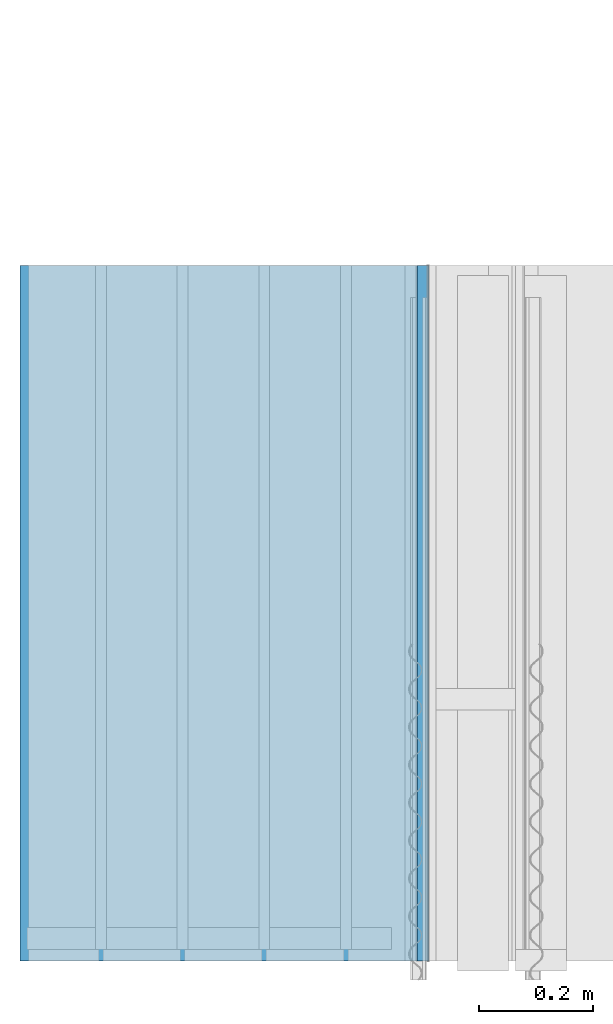
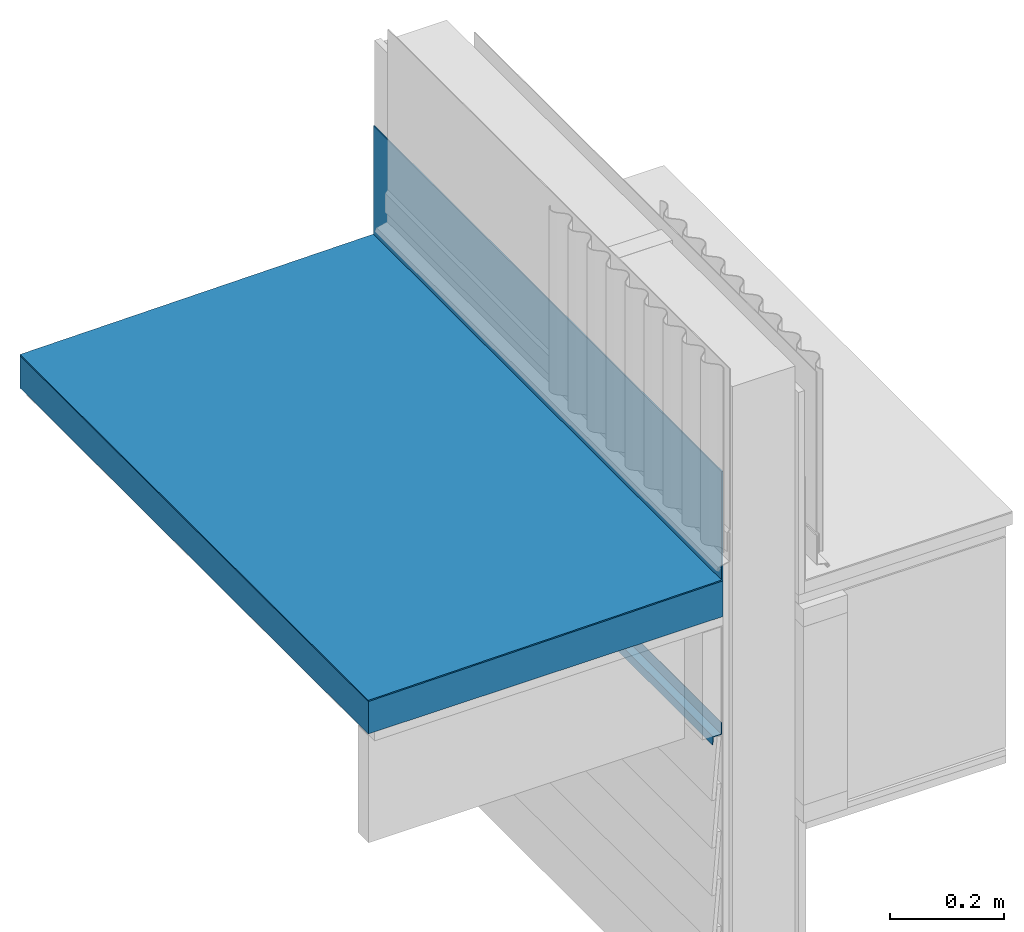
# One storey, part 8 of 33: 3 walls.
"""IFC4 building model written with IfcOpenShell, lengths in feet."""

import ifcopenshell
import ifcopenshell.guid

model = None  # the IFC model being written
_history = None  # IfcOwnerHistory: only IFC2X3 demands one
_inside = {}  # id of a spatial element -> (the spatial element, [elements in it])
_under = {}  # id of a project, library or spatial element -> (it, [spatial elements below it])
_declared = {}  # id of a project -> (the project, [libraries it declares])
_typed = {}  # id of a type object -> (the type object, [elements of that type])
_made_of = {}  # id of a material, layer set ... -> (it, [elements and type objects made of it])


def new_model(schema):
    """Start an empty IFC model of exactly this schema.

    Asked for "IFC4X3", IfcOpenShell would pick the latest addendum, in which some entities
    have other attributes; the version numbers below select the first issue.
    IFC2X3 requires an IfcOwnerHistory on every rooted entity: one is made here for all.
    """
    global model, _history
    if schema == "IFC4X3":
        model = ifcopenshell.file(schema_version=(4, 3, 0, 0))
    else:
        model = ifcopenshell.file(schema=schema)
    _inside.clear()
    _under.clear()
    _declared.clear()
    _typed.clear()
    _made_of.clear()
    _history = None
    if model.schema == "IFC2X3":
        org = make("IfcOrganization", Name="unknown")
        user = make(
            "IfcPersonAndOrganization",
            ThePerson=make("IfcPerson", FamilyName="unknown"),
            TheOrganization=org,
        )
        app = make(
            "IfcApplication",
            ApplicationDeveloper=org,
            Version="unknown",
            ApplicationFullName="unknown",
            ApplicationIdentifier="unknown",
        )
        _history = make(
            "IfcOwnerHistory",
            OwningUser=user,
            OwningApplication=app,
            ChangeAction="ADDED",
            CreationDate=0,
        )
    return model


def make(cls, **values):
    """One entity of the class cls with the attributes given. An attribute that is None is left unset."""
    return model.create_entity(
        cls, **{name: value for name, value in values.items() if value is not None}
    )


def entity(cls, *values):
    """Any entity or typed value of the class cls, its attributes in the order of the schema. None: left unset."""
    e = model.create_entity(cls)
    for i, value in enumerate(values):
        if value is not None:
            e[i] = value
    return e


def rooted(cls, **values):
    """An entity with a GlobalId (a new one), such as an element, a storey or a relation."""
    return make(cls, GlobalId=ifcopenshell.guid.new(), OwnerHistory=_history, **values)


def si_unit(unit_type, name, prefix=None):
    """IfcSIUnit, for example si_unit("LENGTHUNIT", "METRE", prefix="MILLI")."""
    return make("IfcSIUnit", UnitType=unit_type, Prefix=prefix, Name=name)


def converted_unit(unit_type, name, factor, base, dimensions=None, offset=None):
    """IfcConversionBasedUnit, such as the inch: factor (a typed value) times the base unit."""
    return make(
        "IfcConversionBasedUnit"
        if offset is None
        else "IfcConversionBasedUnitWithOffset",
        ConversionOffset=offset,
        Dimensions=None
        if dimensions is None
        else entity("IfcDimensionalExponents", *dimensions),
        UnitType=unit_type,
        Name=name,
        ConversionFactor=make(
            "IfcMeasureWithUnit", ValueComponent=factor, UnitComponent=base
        ),
    )


def derived_unit(unit_type, elements):
    """IfcDerivedUnit: a product of units, each with its exponent."""
    return make(
        "IfcDerivedUnit",
        Elements=[
            make("IfcDerivedUnitElement", Unit=unit, Exponent=power)
            for unit, power in elements
        ],
        UnitType=unit_type,
    )


def assignment(units):
    """IfcUnitAssignment: the units of a project."""
    return None if units is None else make("IfcUnitAssignment", Units=units)


def point(xyz):
    """IfcCartesianPoint."""
    return None if xyz is None else make("IfcCartesianPoint", Coordinates=xyz)


def direction(xyz):
    """IfcDirection."""
    return None if xyz is None else make("IfcDirection", DirectionRatios=xyz)


def frame(location, z_axis=None, x_axis=None):
    """IfcAxis2Placement3D, a coordinate frame: its origin and axes. An axis left out is left unset."""
    return make(
        "IfcAxis2Placement3D",
        Location=point(location),
        Axis=direction(z_axis),
        RefDirection=direction(x_axis),
    )


def origin():
    """The frame at (0, 0, 0) with its axes left unset."""
    return frame((0.0, 0.0, 0.0))


def place(relative_to, where):
    """IfcLocalPlacement: puts the frame where relative to a parent placement (None: the world)."""
    return make(
        "IfcLocalPlacement", PlacementRelTo=relative_to, RelativePlacement=where
    )


def context(
    kind, dimensions, precision=None, world=None, true_north=None, identifier=None
):
    """IfcGeometricRepresentationContext, for example the 3D "Model" context."""
    return make(
        "IfcGeometricRepresentationContext",
        ContextIdentifier=identifier,
        ContextType=kind,
        CoordinateSpaceDimension=dimensions,
        Precision=precision,
        WorldCoordinateSystem=world,
        TrueNorth=true_north,
    )


def subcontext(parent, identifier, kind, view, scale=None):
    """IfcGeometricRepresentationSubContext, for example "Body" below "Model"."""
    return make(
        "IfcGeometricRepresentationSubContext",
        ContextIdentifier=identifier,
        ContextType=kind,
        ParentContext=parent,
        TargetScale=scale,
        TargetView=view,
    )


def project(units=None, contexts=None):
    """IfcProject with its units and contexts."""
    return rooted(
        "IfcProject",
        Name="project",
        RepresentationContexts=contexts,
        UnitsInContext=assignment(units),
    )


def spatial(cls, under=None, at=None, **own):
    """A site, building, storey or space (cls), placed at a placement, below another one or the project."""
    s = rooted(cls, ObjectPlacement=at, **own)
    if under is not None:
        _under.setdefault(under.id(), (under, []))[1].append(s)
    return s


def shape(context_of_items, identifier, shape_type, items):
    """IfcShapeRepresentation: the items that make up one representation, for example the "Body"."""
    return make(
        "IfcShapeRepresentation",
        ContextOfItems=context_of_items,
        RepresentationIdentifier=identifier,
        RepresentationType=shape_type,
        Items=items,
    )


def material(Name=None, Category=None):
    """IfcMaterial."""
    return make("IfcMaterial", Name=Name, Category=Category)


def made_of(thing, what):
    """Note that an element or type object is made of a material, layer set ...; save() writes the relation."""
    if what is not None:
        _made_of.setdefault(what.id(), (what, []))[1].append(thing)
    return thing


def type_object(cls, material=None, **own):
    """A type object (cls), such as IfcWallType, which elements share."""
    return made_of(rooted(cls, **own), material)


def element(
    cls,
    number,
    at=None,
    inside=None,
    cuts=None,
    type_object=None,
    material=None,
    context=None,
    identifier="Body",
    shape_type=None,
    held_by="IfcProductDefinitionShape",
    body=None,
    shapes=None,
    **own,
):
    """One element of the class cls, such as IfcWall. Its Tag is "e" and its number.

    at: its placement. inside: the storey or other place that contains it. cuts: it is an
    opening in that element (IfcRelVoidsElement). A single representation is given by context,
    identifier, shape_type and body (its items); several are given by shapes. held_by: the class
    of the entity that holds the representations. save() writes the other relations.
    """
    e = rooted(cls, Tag="e%d" % number, ObjectPlacement=at, **own)
    if body is not None:
        shapes = [shape(context, identifier, shape_type, body)]
    if shapes is not None:
        e.Representation = make(held_by, Representations=shapes)
    if inside is not None:
        _inside.setdefault(inside.id(), (inside, []))[1].append(e)
    if cuts is not None:
        rooted(
            "IfcRelVoidsElement", RelatingBuildingElement=cuts, RelatedOpeningElement=e
        )
    if type_object is not None:
        _typed.setdefault(type_object.id(), (type_object, []))[1].append(e)
    return made_of(e, material)


def aggregate(whole, parts):
    """IfcRelAggregates: a whole, such as a stair, and the parts it consists of."""
    return rooted("IfcRelAggregates", RelatingObject=whole, RelatedObjects=parts)


def save(model, path):
    """Write the relations noted so far, then the file.

    IfcRelAggregates (storeys below a building ...), IfcRelContainedInSpatialStructure (elements
    in a storey), IfcRelDefinesByType, IfcRelAssociatesMaterial and IfcRelDeclares: one each for
    every whole, place, type object, material and project.
    """
    for whole, parts in _under.values():
        aggregate(whole, parts)
    for where, things in _inside.values():
        rooted(
            "IfcRelContainedInSpatialStructure",
            RelatedElements=things,
            RelatingStructure=where,
        )
    for kind, things in _typed.values():
        rooted("IfcRelDefinesByType", RelatedObjects=things, RelatingType=kind)
    for what, things in _made_of.values():
        rooted("IfcRelAssociatesMaterial", RelatedObjects=things, RelatingMaterial=what)
    for by, libraries in _declared.values():
        rooted("IfcRelDeclares", RelatingContext=by, RelatedDefinitions=libraries)
    model.write(path)


model = new_model("IFC4")

# Units and contexts
model_context = context("Model", 3, precision=0.0001, world=origin(), true_north=direction((6.12303176911189e-17, 1.0)))
body_context = subcontext(model_context, "Body", "Model", "MODEL_VIEW")
ifc_project = project(units=[converted_unit("LENGTHUNIT", "FOOT", entity("IfcRatioMeasure", 0.3048), si_unit("LENGTHUNIT", "METRE"), dimensions=[1, 0, 0, 0, 0, 0, 0]), converted_unit("AREAUNIT", "SQUARE FOOT", entity("IfcRatioMeasure", 0.09290304), si_unit("AREAUNIT", "SQUARE_METRE"), dimensions=[2, 0, 0, 0, 0, 0, 0]), converted_unit("VOLUMEUNIT", "CUBIC FOOT", entity("IfcRatioMeasure", 0.028316846592), si_unit("VOLUMEUNIT", "CUBIC_METRE"), dimensions=[3, 0, 0, 0, 0, 0, 0]), converted_unit("PLANEANGLEUNIT", "DEGREE", entity("IfcRatioMeasure", 0.0174532925199433), si_unit("PLANEANGLEUNIT", "RADIAN"), dimensions=[0, 0, 0, 0, 0, 0, 0]), si_unit("MASSUNIT", "GRAM", prefix="KILO"), derived_unit("MASSDENSITYUNIT", [(si_unit("MASSUNIT", "GRAM", prefix="KILO"), 1), (si_unit("LENGTHUNIT", "METRE"), -3)]), derived_unit("MOMENTOFINERTIAUNIT", [(si_unit("LENGTHUNIT", "METRE"), 4)]), si_unit("TIMEUNIT", "SECOND"), si_unit("FREQUENCYUNIT", "HERTZ"), si_unit("THERMODYNAMICTEMPERATUREUNIT", "DEGREE_CELSIUS"), derived_unit("THERMALTRANSMITTANCEUNIT", [(si_unit("MASSUNIT", "GRAM", prefix="KILO"), 1), (si_unit("THERMODYNAMICTEMPERATUREUNIT", "KELVIN"), -1), (si_unit("TIMEUNIT", "SECOND"), -3)]), derived_unit("VOLUMETRICFLOWRATEUNIT", [(si_unit("LENGTHUNIT", "METRE"), 3), (si_unit("TIMEUNIT", "SECOND"), -1)]), si_unit("ELECTRICCURRENTUNIT", "AMPERE"), si_unit("ELECTRICVOLTAGEUNIT", "VOLT"), si_unit("POWERUNIT", "WATT"), si_unit("FORCEUNIT", "NEWTON"), si_unit("ILLUMINANCEUNIT", "LUX"), si_unit("LUMINOUSFLUXUNIT", "LUMEN"), si_unit("LUMINOUSINTENSITYUNIT", "CANDELA"), derived_unit("USERDEFINED", [(si_unit("MASSUNIT", "GRAM", prefix="KILO"), -1), (si_unit("LENGTHUNIT", "METRE"), -2), (si_unit("TIMEUNIT", "SECOND"), 3), (si_unit("LUMINOUSFLUXUNIT", "LUMEN"), 1)]), derived_unit("LINEARVELOCITYUNIT", [(si_unit("LENGTHUNIT", "METRE"), 1), (si_unit("TIMEUNIT", "SECOND"), -1)]), si_unit("PRESSUREUNIT", "PASCAL"), derived_unit("USERDEFINED", [(si_unit("LENGTHUNIT", "METRE"), -2), (si_unit("MASSUNIT", "GRAM", prefix="KILO"), 1), (si_unit("TIMEUNIT", "SECOND"), -2)]), derived_unit("LINEARFORCEUNIT", [(si_unit("MASSUNIT", "GRAM", prefix="KILO"), 1), (si_unit("LENGTHUNIT", "METRE"), 1), (si_unit("TIMEUNIT", "SECOND"), -2), (si_unit("LENGTHUNIT", "METRE"), -1)]), derived_unit("PLANARFORCEUNIT", [(si_unit("MASSUNIT", "GRAM", prefix="KILO"), 1), (si_unit("LENGTHUNIT", "METRE"), 1), (si_unit("TIMEUNIT", "SECOND"), -2), (si_unit("LENGTHUNIT", "METRE"), -2)])], contexts=[model_context])

# Site, building, storey
site_placement = place(None, origin())
site = spatial("IfcSite", under=ifc_project, at=site_placement, CompositionType="ELEMENT")
building_placement = place(site_placement, origin())
building = spatial("IfcBuilding", under=site, at=building_placement, CompositionType="ELEMENT")
storey_placement = place(building_placement, frame((0.0, 0.0, 10.0)))
storey = spatial("IfcBuildingStorey", under=building, at=storey_placement, Name="2ND FLOOR", CompositionType="ELEMENT", Elevation=10.0000000000002)

# Walls
ifc_material_1 = material(Name="METAL FLASHING", Category="Materials")
wall_type_1 = type_object("IfcWallType", Name="Generic Models 719:Generic Models 1", PredefinedType="NOTDEFINED", material=ifc_material_1)
wall_1_placement = place(storey_placement, frame((1459.20072375379, 2.0, 21.1496223071839), z_axis=(0.0, 0.0, 1.0), x_axis=(0.0, 1.0, 0.0)))
cartesian_point_1 = entity("IfcCartesianPoint", [4.0, -0.058778221867442, 0.136863440335034])
vertex_point_1 = entity("IfcVertexPoint", cartesian_point_1)
cartesian_point_2 = entity("IfcCartesianPoint", [4.0, -0.0621115552007723, 0.136863440335034])
vertex_point_2 = entity("IfcVertexPoint", cartesian_point_2)
ifc_direction_1 = entity("IfcDirection", [0.0, -1.0, 0.0])
edge_curve_1 = entity("IfcEdgeCurve", vertex_point_1, vertex_point_2, entity("IfcTrimmedCurve", entity("IfcLine", cartesian_point_1, entity("IfcVector", ifc_direction_1, 1.0)), [cartesian_point_1], [cartesian_point_2], True, "CARTESIAN"), True)
cartesian_point_3 = entity("IfcCartesianPoint", [4.0, -0.0621115552007723, 0.0530392484579139])
vertex_point_3 = entity("IfcVertexPoint", cartesian_point_3)
ifc_direction_2 = entity("IfcDirection", [0.0, 0.0, -1.0])
edge_curve_2 = entity("IfcEdgeCurve", vertex_point_2, vertex_point_3, entity("IfcTrimmedCurve", entity("IfcLine", cartesian_point_2, entity("IfcVector", ifc_direction_2, 1.0)), [cartesian_point_2], [cartesian_point_3], True, "CARTESIAN"), True)
cartesian_point_4 = entity("IfcCartesianPoint", [4.0, -0.00778096922499572, 0.0530392484579139])
vertex_point_4 = entity("IfcVertexPoint", cartesian_point_4)
ifc_direction_3 = entity("IfcDirection", [0.0, 1.0, 0.0])
edge_curve_3 = entity("IfcEdgeCurve", vertex_point_3, vertex_point_4, entity("IfcTrimmedCurve", entity("IfcLine", cartesian_point_3, entity("IfcVector", ifc_direction_3, 1.0)), [cartesian_point_3], [cartesian_point_4], True, "CARTESIAN"), True)
cartesian_point_5 = entity("IfcCartesianPoint", [4.0, -0.00326697603304638, 0.0])
vertex_point_5 = entity("IfcVertexPoint", cartesian_point_5)
edge_curve_4 = entity("IfcEdgeCurve", vertex_point_4, vertex_point_5, entity("IfcTrimmedCurve", entity("IfcLine", cartesian_point_4, entity("IfcVector", entity("IfcDirection", [0.0, 0.0848001027005316, -0.996397984031471]), 1.0)), [cartesian_point_4], [cartesian_point_5], True, "CARTESIAN"), True)
cartesian_point_6 = entity("IfcCartesianPoint", [4.0, 0.0, 0.0])
vertex_point_6 = entity("IfcVertexPoint", cartesian_point_6)
edge_curve_5 = entity("IfcEdgeCurve", vertex_point_5, vertex_point_6, entity("IfcTrimmedCurve", entity("IfcLine", cartesian_point_5, entity("IfcVector", ifc_direction_3, 1.0)), [cartesian_point_5], [cartesian_point_6], True, "CARTESIAN"), True)
cartesian_point_7 = entity("IfcCartesianPoint", [4.0, -0.00480094715771884, 0.0564109466517451])
vertex_point_7 = entity("IfcVertexPoint", cartesian_point_7)
edge_curve_6 = entity("IfcEdgeCurve", vertex_point_6, vertex_point_7, entity("IfcTrimmedCurve", entity("IfcLine", cartesian_point_6, entity("IfcVector", entity("IfcDirection", [0.0, -0.0848001026986147, 0.996397984031634]), 1.0)), [cartesian_point_6], [cartesian_point_7], True, "CARTESIAN"), True)
cartesian_point_8 = entity("IfcCartesianPoint", [4.0, -0.058778221867442, 0.0564109466517451])
vertex_point_8 = entity("IfcVertexPoint", cartesian_point_8)
edge_curve_7 = entity("IfcEdgeCurve", vertex_point_7, vertex_point_8, entity("IfcTrimmedCurve", entity("IfcLine", cartesian_point_7, entity("IfcVector", ifc_direction_1, 1.0)), [cartesian_point_7], [cartesian_point_8], True, "CARTESIAN"), True)
ifc_direction_4 = entity("IfcDirection", [0.0, 0.0, 1.0])
edge_curve_8 = entity("IfcEdgeCurve", vertex_point_8, vertex_point_1, entity("IfcTrimmedCurve", entity("IfcLine", cartesian_point_8, entity("IfcVector", ifc_direction_4, 1.0)), [cartesian_point_8], [cartesian_point_1], True, "CARTESIAN"), True)
ifc_direction_5 = entity("IfcDirection", [1.0, 0.0, 0.0])
cartesian_point_9 = entity("IfcCartesianPoint", [0.0, -0.058778221867442, 0.136863440335041])
vertex_point_9 = entity("IfcVertexPoint", cartesian_point_9)
cartesian_point_10 = entity("IfcCartesianPoint", [0.0, -0.058778221867442, 0.0564109466517522])
vertex_point_10 = entity("IfcVertexPoint", cartesian_point_10)
edge_curve_9 = entity("IfcEdgeCurve", vertex_point_9, vertex_point_10, entity("IfcTrimmedCurve", entity("IfcLine", cartesian_point_9, entity("IfcVector", ifc_direction_2, 1.0)), [cartesian_point_9], [cartesian_point_10], True, "CARTESIAN"), True)
cartesian_point_11 = entity("IfcCartesianPoint", [0.0, -0.00480094715771884, 0.0564109466517522])
vertex_point_11 = entity("IfcVertexPoint", cartesian_point_11)
edge_curve_10 = entity("IfcEdgeCurve", vertex_point_10, vertex_point_11, entity("IfcTrimmedCurve", entity("IfcLine", cartesian_point_10, entity("IfcVector", ifc_direction_3, 1.0)), [cartesian_point_10], [cartesian_point_11], True, "CARTESIAN"), True)
cartesian_point_12 = entity("IfcCartesianPoint", [0.0, 0.0, 0.0])
vertex_point_12 = entity("IfcVertexPoint", cartesian_point_12)
edge_curve_11 = entity("IfcEdgeCurve", vertex_point_11, vertex_point_12, entity("IfcTrimmedCurve", entity("IfcLine", cartesian_point_11, entity("IfcVector", entity("IfcDirection", [0.0, 0.0848001026986147, -0.996397984031634]), 1.0)), [cartesian_point_11], [cartesian_point_12], True, "CARTESIAN"), True)
cartesian_point_13 = entity("IfcCartesianPoint", [0.0, -0.00326697603304638, 0.0])
vertex_point_13 = entity("IfcVertexPoint", cartesian_point_13)
edge_curve_12 = entity("IfcEdgeCurve", vertex_point_12, vertex_point_13, entity("IfcTrimmedCurve", entity("IfcLine", cartesian_point_12, entity("IfcVector", ifc_direction_1, 1.0)), [cartesian_point_12], [cartesian_point_13], True, "CARTESIAN"), True)
cartesian_point_14 = entity("IfcCartesianPoint", [0.0, -0.00778096922499572, 0.053039248457921])
vertex_point_14 = entity("IfcVertexPoint", cartesian_point_14)
edge_curve_13 = entity("IfcEdgeCurve", vertex_point_13, vertex_point_14, entity("IfcTrimmedCurve", entity("IfcLine", cartesian_point_13, entity("IfcVector", entity("IfcDirection", [0.0, -0.0848001027005316, 0.996397984031471]), 1.0)), [cartesian_point_13], [cartesian_point_14], True, "CARTESIAN"), True)
cartesian_point_15 = entity("IfcCartesianPoint", [0.0, -0.0621115552007723, 0.053039248457921])
vertex_point_15 = entity("IfcVertexPoint", cartesian_point_15)
edge_curve_14 = entity("IfcEdgeCurve", vertex_point_14, vertex_point_15, entity("IfcTrimmedCurve", entity("IfcLine", cartesian_point_14, entity("IfcVector", ifc_direction_1, 1.0)), [cartesian_point_14], [cartesian_point_15], True, "CARTESIAN"), True)
cartesian_point_16 = entity("IfcCartesianPoint", [0.0, -0.0621115552007723, 0.136863440335041])
vertex_point_16 = entity("IfcVertexPoint", cartesian_point_16)
edge_curve_15 = entity("IfcEdgeCurve", vertex_point_15, vertex_point_16, entity("IfcTrimmedCurve", entity("IfcLine", cartesian_point_15, entity("IfcVector", ifc_direction_4, 1.0)), [cartesian_point_15], [cartesian_point_16], True, "CARTESIAN"), True)
edge_curve_16 = entity("IfcEdgeCurve", vertex_point_16, vertex_point_9, entity("IfcTrimmedCurve", entity("IfcLine", cartesian_point_16, entity("IfcVector", ifc_direction_3, 1.0)), [cartesian_point_16], [cartesian_point_9], True, "CARTESIAN"), True)
ifc_direction_6 = entity("IfcDirection", [-1.0, 0.0, 0.0])
edge_curve_17 = entity("IfcEdgeCurve", vertex_point_15, vertex_point_3, entity("IfcTrimmedCurve", entity("IfcLine", cartesian_point_15, entity("IfcVector", ifc_direction_5, 1.0)), [cartesian_point_15], [cartesian_point_3], True, "CARTESIAN"), True)
edge_curve_18 = entity("IfcEdgeCurve", vertex_point_2, vertex_point_16, entity("IfcTrimmedCurve", entity("IfcLine", cartesian_point_16, entity("IfcVector", ifc_direction_6, 1.0)), [cartesian_point_2], [cartesian_point_16], True, "CARTESIAN"), True)
edge_curve_19 = entity("IfcEdgeCurve", vertex_point_9, vertex_point_1, entity("IfcTrimmedCurve", entity("IfcLine", cartesian_point_9, entity("IfcVector", ifc_direction_5, 1.0)), [cartesian_point_9], [cartesian_point_1], True, "CARTESIAN"), True)
edge_curve_20 = entity("IfcEdgeCurve", vertex_point_8, vertex_point_10, entity("IfcTrimmedCurve", entity("IfcLine", cartesian_point_10, entity("IfcVector", ifc_direction_6, 1.0)), [cartesian_point_8], [cartesian_point_10], True, "CARTESIAN"), True)
edge_curve_21 = entity("IfcEdgeCurve", vertex_point_7, vertex_point_11, entity("IfcTrimmedCurve", entity("IfcLine", cartesian_point_11, entity("IfcVector", ifc_direction_6, 1.0)), [cartesian_point_7], [cartesian_point_11], True, "CARTESIAN"), True)
edge_curve_22 = entity("IfcEdgeCurve", vertex_point_6, vertex_point_12, entity("IfcTrimmedCurve", entity("IfcLine", cartesian_point_12, entity("IfcVector", ifc_direction_6, 1.0)), [cartesian_point_6], [cartesian_point_12], True, "CARTESIAN"), True)
edge_curve_23 = entity("IfcEdgeCurve", vertex_point_5, vertex_point_13, entity("IfcTrimmedCurve", entity("IfcLine", cartesian_point_13, entity("IfcVector", ifc_direction_6, 1.0)), [cartesian_point_5], [cartesian_point_13], True, "CARTESIAN"), True)
edge_curve_24 = entity("IfcEdgeCurve", vertex_point_4, vertex_point_14, entity("IfcTrimmedCurve", entity("IfcLine", cartesian_point_14, entity("IfcVector", ifc_direction_6, 1.0)), [cartesian_point_4], [cartesian_point_14], True, "CARTESIAN"), True)
element("IfcWall", 1, at=wall_1_placement, inside=storey, type_object=wall_type_1, material=ifc_material_1, Name="Generic Models 719:Generic Models 1", ObjectType="Generic Models 719:Generic Models 1", PredefinedType="NOTDEFINED", context=body_context, shape_type="AdvancedBrep", body=[
    entity("IfcAdvancedBrep", entity("IfcClosedShell", [entity("IfcAdvancedFace", [entity("IfcFaceOuterBound", entity("IfcEdgeLoop", [entity("IfcOrientedEdge", None, None, edge_curve_1, True), entity("IfcOrientedEdge", None, None, edge_curve_2, True), entity("IfcOrientedEdge", None, None, edge_curve_3, True), entity("IfcOrientedEdge", None, None, edge_curve_4, True), entity("IfcOrientedEdge", None, None, edge_curve_5, True), entity("IfcOrientedEdge", None, None, edge_curve_6, True), entity("IfcOrientedEdge", None, None, edge_curve_7, True), entity("IfcOrientedEdge", None, None, edge_curve_8, True)]), True)], entity("IfcPlane", entity("IfcAxis2Placement3D", entity("IfcCartesianPoint", [4.0, -0.058778221867442, -9.23241093280805]), ifc_direction_5, ifc_direction_4)), True), entity("IfcAdvancedFace", [entity("IfcFaceOuterBound", entity("IfcEdgeLoop", [entity("IfcOrientedEdge", None, None, edge_curve_9, True), entity("IfcOrientedEdge", None, None, edge_curve_10, True), entity("IfcOrientedEdge", None, None, edge_curve_11, True), entity("IfcOrientedEdge", None, None, edge_curve_12, True), entity("IfcOrientedEdge", None, None, edge_curve_13, True), entity("IfcOrientedEdge", None, None, edge_curve_14, True), entity("IfcOrientedEdge", None, None, edge_curve_15, True), entity("IfcOrientedEdge", None, None, edge_curve_16, True)]), True)], entity("IfcPlane", entity("IfcAxis2Placement3D", entity("IfcCartesianPoint", [0.0, -0.058778221867442, -9.23241093280804]), ifc_direction_6, ifc_direction_2)), True), entity("IfcAdvancedFace", [entity("IfcFaceOuterBound", entity("IfcEdgeLoop", [entity("IfcOrientedEdge", None, None, edge_curve_15, False), entity("IfcOrientedEdge", None, None, edge_curve_17, True), entity("IfcOrientedEdge", None, None, edge_curve_2, False), entity("IfcOrientedEdge", None, None, edge_curve_18, True)]), True)], entity("IfcPlane", entity("IfcAxis2Placement3D", cartesian_point_15, ifc_direction_1, ifc_direction_5)), True), entity("IfcAdvancedFace", [entity("IfcFaceOuterBound", entity("IfcEdgeLoop", [entity("IfcOrientedEdge", None, None, edge_curve_9, False), entity("IfcOrientedEdge", None, None, edge_curve_19, True), entity("IfcOrientedEdge", None, None, edge_curve_8, False), entity("IfcOrientedEdge", None, None, edge_curve_20, True)]), True)], entity("IfcPlane", entity("IfcAxis2Placement3D", cartesian_point_9, ifc_direction_3, ifc_direction_5)), True), entity("IfcAdvancedFace", [entity("IfcFaceOuterBound", entity("IfcEdgeLoop", [entity("IfcOrientedEdge", None, None, edge_curve_10, False), entity("IfcOrientedEdge", None, None, edge_curve_20, False), entity("IfcOrientedEdge", None, None, edge_curve_7, False), entity("IfcOrientedEdge", None, None, edge_curve_21, True)]), True)], entity("IfcPlane", entity("IfcAxis2Placement3D", cartesian_point_10, ifc_direction_4, ifc_direction_5)), True), entity("IfcAdvancedFace", [entity("IfcFaceOuterBound", entity("IfcEdgeLoop", [entity("IfcOrientedEdge", None, None, edge_curve_11, False), entity("IfcOrientedEdge", None, None, edge_curve_21, False), entity("IfcOrientedEdge", None, None, edge_curve_6, False), entity("IfcOrientedEdge", None, None, edge_curve_22, True)]), True)], entity("IfcPlane", entity("IfcAxis2Placement3D", cartesian_point_11, entity("IfcDirection", [0.0, 0.996397984031634, 0.08480010269862]), ifc_direction_5)), True), entity("IfcAdvancedFace", [entity("IfcFaceOuterBound", entity("IfcEdgeLoop", [entity("IfcOrientedEdge", None, None, edge_curve_12, False), entity("IfcOrientedEdge", None, None, edge_curve_22, False), entity("IfcOrientedEdge", None, None, edge_curve_5, False), entity("IfcOrientedEdge", None, None, edge_curve_23, True)]), True)], entity("IfcPlane", entity("IfcAxis2Placement3D", cartesian_point_12, ifc_direction_2, ifc_direction_5)), True), entity("IfcAdvancedFace", [entity("IfcFaceOuterBound", entity("IfcEdgeLoop", [entity("IfcOrientedEdge", None, None, edge_curve_13, False), entity("IfcOrientedEdge", None, None, edge_curve_23, False), entity("IfcOrientedEdge", None, None, edge_curve_4, False), entity("IfcOrientedEdge", None, None, edge_curve_24, True)]), True)], entity("IfcPlane", entity("IfcAxis2Placement3D", cartesian_point_13, entity("IfcDirection", [0.0, -0.996397984031471, -0.0848001027005344]), ifc_direction_5)), True), entity("IfcAdvancedFace", [entity("IfcFaceOuterBound", entity("IfcEdgeLoop", [entity("IfcOrientedEdge", None, None, edge_curve_14, False), entity("IfcOrientedEdge", None, None, edge_curve_24, False), entity("IfcOrientedEdge", None, None, edge_curve_3, False), entity("IfcOrientedEdge", None, None, edge_curve_17, False)]), True)], entity("IfcPlane", entity("IfcAxis2Placement3D", cartesian_point_14, ifc_direction_2, ifc_direction_5)), True), entity("IfcAdvancedFace", [entity("IfcFaceOuterBound", entity("IfcEdgeLoop", [entity("IfcOrientedEdge", None, None, edge_curve_16, False), entity("IfcOrientedEdge", None, None, edge_curve_18, False), entity("IfcOrientedEdge", None, None, edge_curve_1, False), entity("IfcOrientedEdge", None, None, edge_curve_19, False)]), True)], entity("IfcPlane", entity("IfcAxis2Placement3D", cartesian_point_16, ifc_direction_4, ifc_direction_5)), True)])),
])
ifc_material_2 = material(Name="TAPERED RIGID INSULATION - FOR DRAINAGE", Category="Materials")
wall_type_2 = type_object("IfcWallType", Name="Generic Models 703:Generic Models 1", PredefinedType="NOTDEFINED", material=ifc_material_2)
wall_2_placement = place(storey_placement, frame((1456.91779168788, 2.0, 22.0269119498215), z_axis=(0.0, 0.0, 1.0), x_axis=(0.0, 1.0, 0.0)))
cartesian_point_17 = entity("IfcCartesianPoint", [4.0, 0.0, 0.0])
vertex_point_17 = entity("IfcVertexPoint", cartesian_point_17)
cartesian_point_18 = entity("IfcCartesianPoint", [4.0, 0.0, 0.226764478629022])
vertex_point_18 = entity("IfcVertexPoint", cartesian_point_18)
ifc_direction_7 = entity("IfcDirection", [0.0, 0.0, 1.0])
edge_curve_25 = entity("IfcEdgeCurve", vertex_point_17, vertex_point_18, entity("IfcTrimmedCurve", entity("IfcLine", cartesian_point_17, entity("IfcVector", ifc_direction_7, 1.0)), [cartesian_point_17], [cartesian_point_18], True, "CARTESIAN"), True)
cartesian_point_19 = entity("IfcCartesianPoint", [4.0, -2.35135036593329, 0.24999917098792])
vertex_point_19 = entity("IfcVertexPoint", cartesian_point_19)
edge_curve_26 = entity("IfcEdgeCurve", vertex_point_18, vertex_point_19, entity("IfcTrimmedCurve", entity("IfcLine", cartesian_point_18, entity("IfcVector", entity("IfcDirection", [0.0, -0.999951182294679, 0.00988094264093697]), 1.0)), [cartesian_point_18], [cartesian_point_19], True, "CARTESIAN"), True)
cartesian_point_20 = entity("IfcCartesianPoint", [4.0, -2.35135036593329, 0.0])
vertex_point_20 = entity("IfcVertexPoint", cartesian_point_20)
ifc_direction_8 = entity("IfcDirection", [0.0, 0.0, -1.0])
edge_curve_27 = entity("IfcEdgeCurve", vertex_point_19, vertex_point_20, entity("IfcTrimmedCurve", entity("IfcLine", cartesian_point_19, entity("IfcVector", ifc_direction_8, 1.0)), [cartesian_point_19], [cartesian_point_20], True, "CARTESIAN"), True)
ifc_direction_9 = entity("IfcDirection", [0.0, 1.0, 0.0])
edge_curve_28 = entity("IfcEdgeCurve", vertex_point_20, vertex_point_17, entity("IfcTrimmedCurve", entity("IfcLine", cartesian_point_20, entity("IfcVector", ifc_direction_9, 1.0)), [cartesian_point_20], [cartesian_point_17], True, "CARTESIAN"), True)
ifc_direction_10 = entity("IfcDirection", [1.0, 0.0, 0.0])
cartesian_point_21 = entity("IfcCartesianPoint", [0.0, 0.0, 0.0])
vertex_point_21 = entity("IfcVertexPoint", cartesian_point_21)
cartesian_point_22 = entity("IfcCartesianPoint", [0.0, -2.35135036593329, 0.0])
vertex_point_22 = entity("IfcVertexPoint", cartesian_point_22)
ifc_direction_11 = entity("IfcDirection", [0.0, -1.0, 0.0])
edge_curve_29 = entity("IfcEdgeCurve", vertex_point_21, vertex_point_22, entity("IfcTrimmedCurve", entity("IfcLine", cartesian_point_21, entity("IfcVector", ifc_direction_11, 1.0)), [cartesian_point_21], [cartesian_point_22], True, "CARTESIAN"), True)
cartesian_point_23 = entity("IfcCartesianPoint", [0.0, -2.35135036593329, 0.24999917098792])
vertex_point_23 = entity("IfcVertexPoint", cartesian_point_23)
edge_curve_30 = entity("IfcEdgeCurve", vertex_point_22, vertex_point_23, entity("IfcTrimmedCurve", entity("IfcLine", cartesian_point_22, entity("IfcVector", ifc_direction_7, 1.0)), [cartesian_point_22], [cartesian_point_23], True, "CARTESIAN"), True)
cartesian_point_24 = entity("IfcCartesianPoint", [0.0, 0.0, 0.226764478629022])
vertex_point_24 = entity("IfcVertexPoint", cartesian_point_24)
edge_curve_31 = entity("IfcEdgeCurve", vertex_point_23, vertex_point_24, entity("IfcTrimmedCurve", entity("IfcLine", cartesian_point_23, entity("IfcVector", entity("IfcDirection", [0.0, 0.999951182294679, -0.00988094264093697]), 1.0)), [cartesian_point_23], [cartesian_point_24], True, "CARTESIAN"), True)
edge_curve_32 = entity("IfcEdgeCurve", vertex_point_24, vertex_point_21, entity("IfcTrimmedCurve", entity("IfcLine", cartesian_point_24, entity("IfcVector", ifc_direction_8, 1.0)), [cartesian_point_24], [cartesian_point_21], True, "CARTESIAN"), True)
ifc_direction_12 = entity("IfcDirection", [-1.0, 0.0, 0.0])
edge_curve_33 = entity("IfcEdgeCurve", vertex_point_24, vertex_point_18, entity("IfcTrimmedCurve", entity("IfcLine", cartesian_point_24, entity("IfcVector", ifc_direction_10, 1.0)), [cartesian_point_24], [cartesian_point_18], True, "CARTESIAN"), True)
edge_curve_34 = entity("IfcEdgeCurve", vertex_point_17, vertex_point_21, entity("IfcTrimmedCurve", entity("IfcLine", cartesian_point_21, entity("IfcVector", ifc_direction_12, 1.0)), [cartesian_point_17], [cartesian_point_21], True, "CARTESIAN"), True)
edge_curve_35 = entity("IfcEdgeCurve", vertex_point_20, vertex_point_22, entity("IfcTrimmedCurve", entity("IfcLine", cartesian_point_22, entity("IfcVector", ifc_direction_12, 1.0)), [cartesian_point_20], [cartesian_point_22], True, "CARTESIAN"), True)
edge_curve_36 = entity("IfcEdgeCurve", vertex_point_19, vertex_point_23, entity("IfcTrimmedCurve", entity("IfcLine", cartesian_point_23, entity("IfcVector", ifc_direction_12, 1.0)), [cartesian_point_19], [cartesian_point_23], True, "CARTESIAN"), True)
element("IfcWall", 2, at=wall_2_placement, inside=storey, type_object=wall_type_2, material=ifc_material_2, Name="Generic Models 703:Generic Models 1", ObjectType="Generic Models 703:Generic Models 1", PredefinedType="NOTDEFINED", context=body_context, shape_type="AdvancedBrep", body=[
    entity("IfcAdvancedBrep", entity("IfcClosedShell", [entity("IfcAdvancedFace", [entity("IfcFaceOuterBound", entity("IfcEdgeLoop", [entity("IfcOrientedEdge", None, None, edge_curve_25, True), entity("IfcOrientedEdge", None, None, edge_curve_26, True), entity("IfcOrientedEdge", None, None, edge_curve_27, True), entity("IfcOrientedEdge", None, None, edge_curve_28, True)]), True)], entity("IfcPlane", entity("IfcAxis2Placement3D", cartesian_point_20, ifc_direction_10, ifc_direction_9)), True), entity("IfcAdvancedFace", [entity("IfcFaceOuterBound", entity("IfcEdgeLoop", [entity("IfcOrientedEdge", None, None, edge_curve_29, True), entity("IfcOrientedEdge", None, None, edge_curve_30, True), entity("IfcOrientedEdge", None, None, edge_curve_31, True), entity("IfcOrientedEdge", None, None, edge_curve_32, True)]), True)], entity("IfcPlane", entity("IfcAxis2Placement3D", cartesian_point_22, ifc_direction_12, ifc_direction_11)), True), entity("IfcAdvancedFace", [entity("IfcFaceOuterBound", entity("IfcEdgeLoop", [entity("IfcOrientedEdge", None, None, edge_curve_32, False), entity("IfcOrientedEdge", None, None, edge_curve_33, True), entity("IfcOrientedEdge", None, None, edge_curve_25, False), entity("IfcOrientedEdge", None, None, edge_curve_34, True)]), True)], entity("IfcPlane", entity("IfcAxis2Placement3D", cartesian_point_24, ifc_direction_9, ifc_direction_10)), True), entity("IfcAdvancedFace", [entity("IfcFaceOuterBound", entity("IfcEdgeLoop", [entity("IfcOrientedEdge", None, None, edge_curve_29, False), entity("IfcOrientedEdge", None, None, edge_curve_34, False), entity("IfcOrientedEdge", None, None, edge_curve_28, False), entity("IfcOrientedEdge", None, None, edge_curve_35, True)]), True)], entity("IfcPlane", entity("IfcAxis2Placement3D", cartesian_point_21, ifc_direction_8, ifc_direction_10)), True), entity("IfcAdvancedFace", [entity("IfcFaceOuterBound", entity("IfcEdgeLoop", [entity("IfcOrientedEdge", None, None, edge_curve_30, False), entity("IfcOrientedEdge", None, None, edge_curve_35, False), entity("IfcOrientedEdge", None, None, edge_curve_27, False), entity("IfcOrientedEdge", None, None, edge_curve_36, True)]), True)], entity("IfcPlane", entity("IfcAxis2Placement3D", cartesian_point_22, ifc_direction_11, ifc_direction_10)), True), entity("IfcAdvancedFace", [entity("IfcFaceOuterBound", entity("IfcEdgeLoop", [entity("IfcOrientedEdge", None, None, edge_curve_31, False), entity("IfcOrientedEdge", None, None, edge_curve_36, False), entity("IfcOrientedEdge", None, None, edge_curve_26, False), entity("IfcOrientedEdge", None, None, edge_curve_33, False)]), True)], entity("IfcPlane", entity("IfcAxis2Placement3D", cartesian_point_23, entity("IfcDirection", [0.0, 0.00988094264093848, 0.999951182294679]), ifc_direction_10)), True)])),
])
ifc_material_3 = material(Name="TPO ROOFING MEMBRANE", Category="Materials")
wall_type_3 = type_object("IfcWallType", Name="Generic Models 704:Generic Models 1", PredefinedType="NOTDEFINED", material=ifc_material_3)
wall_3_placement = place(storey_placement, frame((1456.91779168788, 2.0, 22.2536764284505), z_axis=(0.0, 0.0, 1.0), x_axis=(0.0, 1.0, 0.0)))
cartesian_point_25 = entity("IfcCartesianPoint", [4.0, 0.0, 0.0])
vertex_point_25 = entity("IfcVertexPoint", cartesian_point_25)
cartesian_point_26 = entity("IfcCartesianPoint", [4.0, 0.0, 0.00876907242503222])
vertex_point_26 = entity("IfcVertexPoint", cartesian_point_26)
ifc_direction_13 = entity("IfcDirection", [0.0, 0.0, 1.0])
edge_curve_37 = entity("IfcEdgeCurve", vertex_point_25, vertex_point_26, entity("IfcTrimmedCurve", entity("IfcLine", cartesian_point_25, entity("IfcVector", ifc_direction_13, 1.0)), [cartesian_point_25], [cartesian_point_26], True, "CARTESIAN"), True)
cartesian_point_27 = entity("IfcCartesianPoint", [4.0, -2.34317891456499, 0.0319230191998585])
vertex_point_27 = entity("IfcVertexPoint", cartesian_point_27)
edge_curve_38 = entity("IfcEdgeCurve", vertex_point_26, vertex_point_27, entity("IfcTrimmedCurve", entity("IfcLine", cartesian_point_26, entity("IfcVector", entity("IfcDirection", [0.0, -0.999951182294679, 0.00988094264093954]), 1.0)), [cartesian_point_26], [cartesian_point_27], True, "CARTESIAN"), True)
cartesian_point_28 = entity("IfcCartesianPoint", [4.0, -2.34317891456499, 0.791444061955957])
vertex_point_28 = entity("IfcVertexPoint", cartesian_point_28)
edge_curve_39 = entity("IfcEdgeCurve", vertex_point_27, vertex_point_28, entity("IfcTrimmedCurve", entity("IfcLine", cartesian_point_27, entity("IfcVector", ifc_direction_13, 1.0)), [cartesian_point_27], [cartesian_point_28], True, "CARTESIAN"), True)
cartesian_point_29 = entity("IfcCartesianPoint", [4.0, -2.35135036593329, 0.791444061955957])
vertex_point_29 = entity("IfcVertexPoint", cartesian_point_29)
ifc_direction_14 = entity("IfcDirection", [0.0, -1.0, 0.0])
edge_curve_40 = entity("IfcEdgeCurve", vertex_point_28, vertex_point_29, entity("IfcTrimmedCurve", entity("IfcLine", cartesian_point_28, entity("IfcVector", ifc_direction_14, 1.0)), [cartesian_point_28], [cartesian_point_29], True, "CARTESIAN"), True)
cartesian_point_30 = entity("IfcCartesianPoint", [4.0, -2.35135036593329, 0.0232346923588977])
vertex_point_30 = entity("IfcVertexPoint", cartesian_point_30)
ifc_direction_15 = entity("IfcDirection", [0.0, 0.0, -1.0])
edge_curve_41 = entity("IfcEdgeCurve", vertex_point_29, vertex_point_30, entity("IfcTrimmedCurve", entity("IfcLine", cartesian_point_29, entity("IfcVector", ifc_direction_15, 1.0)), [cartesian_point_29], [cartesian_point_30], True, "CARTESIAN"), True)
edge_curve_42 = entity("IfcEdgeCurve", vertex_point_30, vertex_point_25, entity("IfcTrimmedCurve", entity("IfcLine", cartesian_point_30, entity("IfcVector", entity("IfcDirection", [0.0, 0.999951182294679, -0.00988094264093999]), 1.0)), [cartesian_point_30], [cartesian_point_25], True, "CARTESIAN"), True)
ifc_direction_16 = entity("IfcDirection", [1.0, 0.0, 0.0])
cartesian_point_31 = entity("IfcCartesianPoint", [0.0, 0.0, 0.0])
vertex_point_31 = entity("IfcVertexPoint", cartesian_point_31)
cartesian_point_32 = entity("IfcCartesianPoint", [0.0, -2.35135036593329, 0.0232346923588977])
vertex_point_32 = entity("IfcVertexPoint", cartesian_point_32)
edge_curve_43 = entity("IfcEdgeCurve", vertex_point_31, vertex_point_32, entity("IfcTrimmedCurve", entity("IfcLine", cartesian_point_31, entity("IfcVector", entity("IfcDirection", [0.0, -0.999951182294679, 0.00988094264093999]), 1.0)), [cartesian_point_31], [cartesian_point_32], True, "CARTESIAN"), True)
cartesian_point_33 = entity("IfcCartesianPoint", [0.0, -2.35135036593329, 0.791444061955957])
vertex_point_33 = entity("IfcVertexPoint", cartesian_point_33)
edge_curve_44 = entity("IfcEdgeCurve", vertex_point_32, vertex_point_33, entity("IfcTrimmedCurve", entity("IfcLine", cartesian_point_32, entity("IfcVector", ifc_direction_13, 1.0)), [cartesian_point_32], [cartesian_point_33], True, "CARTESIAN"), True)
cartesian_point_34 = entity("IfcCartesianPoint", [0.0, -2.34317891456499, 0.791444061955957])
vertex_point_34 = entity("IfcVertexPoint", cartesian_point_34)
ifc_direction_17 = entity("IfcDirection", [0.0, 1.0, 0.0])
edge_curve_45 = entity("IfcEdgeCurve", vertex_point_33, vertex_point_34, entity("IfcTrimmedCurve", entity("IfcLine", cartesian_point_33, entity("IfcVector", ifc_direction_17, 1.0)), [cartesian_point_33], [cartesian_point_34], True, "CARTESIAN"), True)
cartesian_point_35 = entity("IfcCartesianPoint", [0.0, -2.34317891456499, 0.0319230191998585])
vertex_point_35 = entity("IfcVertexPoint", cartesian_point_35)
edge_curve_46 = entity("IfcEdgeCurve", vertex_point_34, vertex_point_35, entity("IfcTrimmedCurve", entity("IfcLine", cartesian_point_34, entity("IfcVector", ifc_direction_15, 1.0)), [cartesian_point_34], [cartesian_point_35], True, "CARTESIAN"), True)
cartesian_point_36 = entity("IfcCartesianPoint", [0.0, 0.0, 0.00876907242503222])
vertex_point_36 = entity("IfcVertexPoint", cartesian_point_36)
edge_curve_47 = entity("IfcEdgeCurve", vertex_point_35, vertex_point_36, entity("IfcTrimmedCurve", entity("IfcLine", cartesian_point_35, entity("IfcVector", entity("IfcDirection", [0.0, 0.999951182294679, -0.00988094264093954]), 1.0)), [cartesian_point_35], [cartesian_point_36], True, "CARTESIAN"), True)
edge_curve_48 = entity("IfcEdgeCurve", vertex_point_36, vertex_point_31, entity("IfcTrimmedCurve", entity("IfcLine", cartesian_point_36, entity("IfcVector", ifc_direction_15, 1.0)), [cartesian_point_36], [cartesian_point_31], True, "CARTESIAN"), True)
ifc_direction_18 = entity("IfcDirection", [-1.0, 0.0, 0.0])
edge_curve_49 = entity("IfcEdgeCurve", vertex_point_36, vertex_point_26, entity("IfcTrimmedCurve", entity("IfcLine", cartesian_point_36, entity("IfcVector", ifc_direction_16, 1.0)), [cartesian_point_36], [cartesian_point_26], True, "CARTESIAN"), True)
edge_curve_50 = entity("IfcEdgeCurve", vertex_point_25, vertex_point_31, entity("IfcTrimmedCurve", entity("IfcLine", cartesian_point_31, entity("IfcVector", ifc_direction_18, 1.0)), [cartesian_point_25], [cartesian_point_31], True, "CARTESIAN"), True)
edge_curve_51 = entity("IfcEdgeCurve", vertex_point_30, vertex_point_32, entity("IfcTrimmedCurve", entity("IfcLine", cartesian_point_32, entity("IfcVector", ifc_direction_18, 1.0)), [cartesian_point_30], [cartesian_point_32], True, "CARTESIAN"), True)
edge_curve_52 = entity("IfcEdgeCurve", vertex_point_35, vertex_point_27, entity("IfcTrimmedCurve", entity("IfcLine", cartesian_point_35, entity("IfcVector", ifc_direction_16, 1.0)), [cartesian_point_35], [cartesian_point_27], True, "CARTESIAN"), True)
edge_curve_53 = entity("IfcEdgeCurve", vertex_point_29, vertex_point_33, entity("IfcTrimmedCurve", entity("IfcLine", cartesian_point_33, entity("IfcVector", ifc_direction_18, 1.0)), [cartesian_point_29], [cartesian_point_33], True, "CARTESIAN"), True)
edge_curve_54 = entity("IfcEdgeCurve", vertex_point_28, vertex_point_34, entity("IfcTrimmedCurve", entity("IfcLine", cartesian_point_34, entity("IfcVector", ifc_direction_18, 1.0)), [cartesian_point_28], [cartesian_point_34], True, "CARTESIAN"), True)
element("IfcWall", 3, at=wall_3_placement, inside=storey, type_object=wall_type_3, material=ifc_material_3, Name="Generic Models 704:Generic Models 1", ObjectType="Generic Models 704:Generic Models 1", PredefinedType="NOTDEFINED", context=body_context, shape_type="AdvancedBrep", body=[
    entity("IfcAdvancedBrep", entity("IfcClosedShell", [entity("IfcAdvancedFace", [entity("IfcFaceOuterBound", entity("IfcEdgeLoop", [entity("IfcOrientedEdge", None, None, edge_curve_37, True), entity("IfcOrientedEdge", None, None, edge_curve_38, True), entity("IfcOrientedEdge", None, None, edge_curve_39, True), entity("IfcOrientedEdge", None, None, edge_curve_40, True), entity("IfcOrientedEdge", None, None, edge_curve_41, True), entity("IfcOrientedEdge", None, None, edge_curve_42, True)]), True)], entity("IfcPlane", entity("IfcAxis2Placement3D", entity("IfcCartesianPoint", [4.0, -2.2986850666332, 0.0227142841522081]), ifc_direction_16, entity("IfcDirection", [0.0, 0.999951182294679, -0.00988094264093697]))), True), entity("IfcAdvancedFace", [entity("IfcFaceOuterBound", entity("IfcEdgeLoop", [entity("IfcOrientedEdge", None, None, edge_curve_43, True), entity("IfcOrientedEdge", None, None, edge_curve_44, True), entity("IfcOrientedEdge", None, None, edge_curve_45, True), entity("IfcOrientedEdge", None, None, edge_curve_46, True), entity("IfcOrientedEdge", None, None, edge_curve_47, True), entity("IfcOrientedEdge", None, None, edge_curve_48, True)]), True)], entity("IfcPlane", entity("IfcAxis2Placement3D", entity("IfcCartesianPoint", [0.0, -2.2986850666332, 0.0227142841522081]), ifc_direction_18, entity("IfcDirection", [0.0, -0.999951182294679, 0.00988094264093697]))), True), entity("IfcAdvancedFace", [entity("IfcFaceOuterBound", entity("IfcEdgeLoop", [entity("IfcOrientedEdge", None, None, edge_curve_48, False), entity("IfcOrientedEdge", None, None, edge_curve_49, True), entity("IfcOrientedEdge", None, None, edge_curve_37, False), entity("IfcOrientedEdge", None, None, edge_curve_50, True)]), True)], entity("IfcPlane", entity("IfcAxis2Placement3D", cartesian_point_36, ifc_direction_17, ifc_direction_16)), True), entity("IfcAdvancedFace", [entity("IfcFaceOuterBound", entity("IfcEdgeLoop", [entity("IfcOrientedEdge", None, None, edge_curve_43, False), entity("IfcOrientedEdge", None, None, edge_curve_50, False), entity("IfcOrientedEdge", None, None, edge_curve_42, False), entity("IfcOrientedEdge", None, None, edge_curve_51, True)]), True)], entity("IfcPlane", entity("IfcAxis2Placement3D", cartesian_point_31, entity("IfcDirection", [0.0, -0.00988094264093697, -0.999951182294679]), ifc_direction_16)), True), entity("IfcAdvancedFace", [entity("IfcFaceOuterBound", entity("IfcEdgeLoop", [entity("IfcOrientedEdge", None, None, edge_curve_47, False), entity("IfcOrientedEdge", None, None, edge_curve_52, True), entity("IfcOrientedEdge", None, None, edge_curve_38, False), entity("IfcOrientedEdge", None, None, edge_curve_49, False)]), True)], entity("IfcPlane", entity("IfcAxis2Placement3D", cartesian_point_35, entity("IfcDirection", [0.0, 0.00988094264093651, 0.999951182294679]), ifc_direction_16)), True), entity("IfcAdvancedFace", [entity("IfcFaceOuterBound", entity("IfcEdgeLoop", [entity("IfcOrientedEdge", None, None, edge_curve_44, False), entity("IfcOrientedEdge", None, None, edge_curve_51, False), entity("IfcOrientedEdge", None, None, edge_curve_41, False), entity("IfcOrientedEdge", None, None, edge_curve_53, True)]), True)], entity("IfcPlane", entity("IfcAxis2Placement3D", cartesian_point_32, ifc_direction_14, ifc_direction_16)), True), entity("IfcAdvancedFace", [entity("IfcFaceOuterBound", entity("IfcEdgeLoop", [entity("IfcOrientedEdge", None, None, edge_curve_45, False), entity("IfcOrientedEdge", None, None, edge_curve_53, False), entity("IfcOrientedEdge", None, None, edge_curve_40, False), entity("IfcOrientedEdge", None, None, edge_curve_54, True)]), True)], entity("IfcPlane", entity("IfcAxis2Placement3D", cartesian_point_33, ifc_direction_13, ifc_direction_16)), True), entity("IfcAdvancedFace", [entity("IfcFaceOuterBound", entity("IfcEdgeLoop", [entity("IfcOrientedEdge", None, None, edge_curve_46, False), entity("IfcOrientedEdge", None, None, edge_curve_54, False), entity("IfcOrientedEdge", None, None, edge_curve_39, False), entity("IfcOrientedEdge", None, None, edge_curve_52, False)]), True)], entity("IfcPlane", entity("IfcAxis2Placement3D", cartesian_point_34, ifc_direction_17, ifc_direction_16)), True)])),
])

save(model, "model.ifc")
